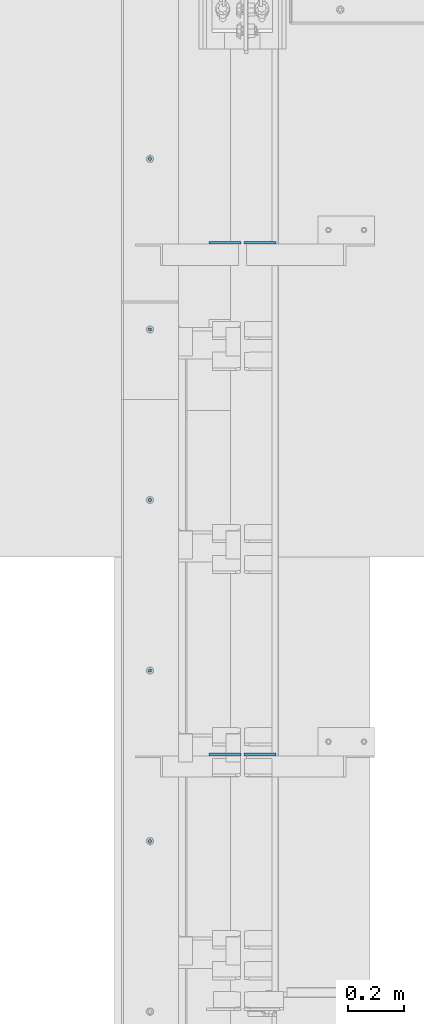
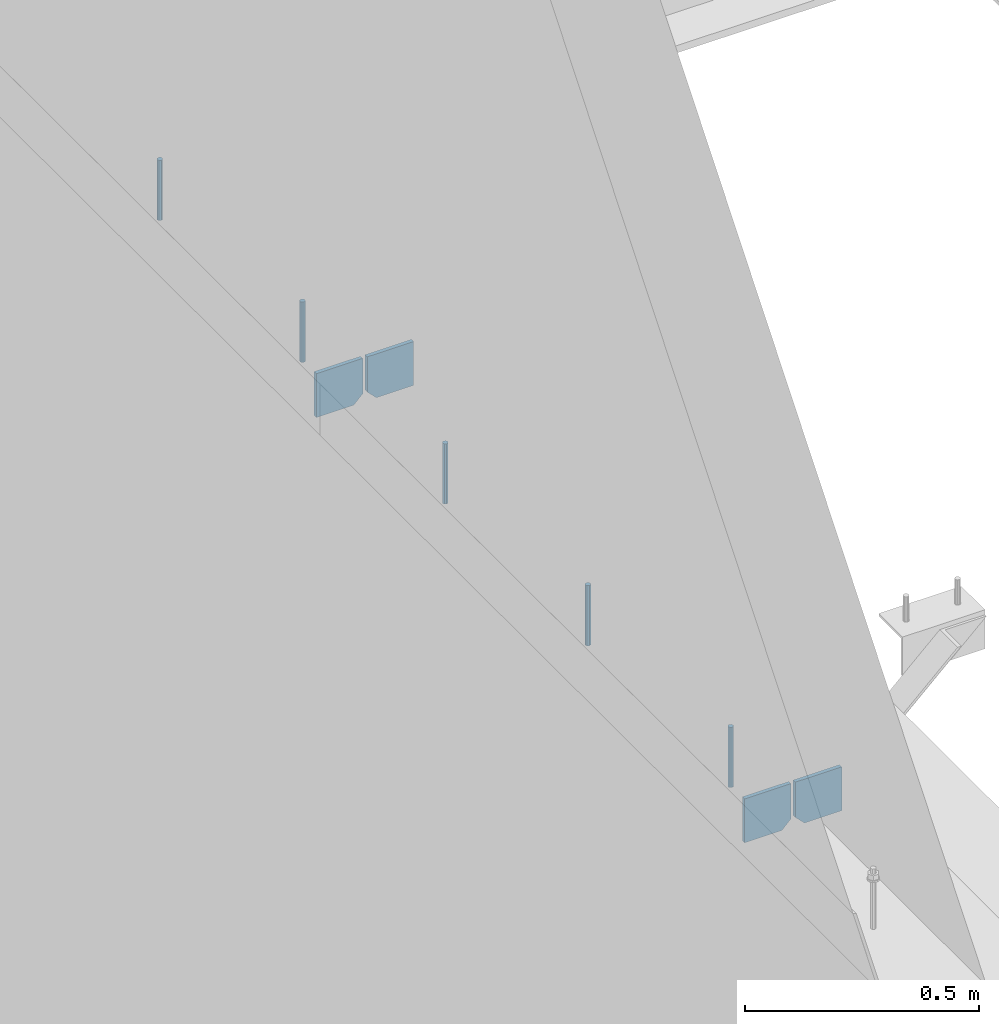
# One storey, part 421 of 1179: 9 columns, 1 element without a shape of its own.
"""IFC2X3 building model written with IfcOpenShell, lengths in millimetres."""

from ifc_helpers import new_model, si_unit, frame, origin_with_axes, place, context, subcontext, project, spatial, faceted_brep, material, type_object, element, aggregate, save


model = new_model("IFC2X3")

# Units and contexts
model_context = context("Model", 3, precision=1e-05, world=origin_with_axes())
body_context = subcontext(model_context, "Body", "Model", "MODEL_VIEW")
ifc_project = project(units=[si_unit("LENGTHUNIT", "METRE", prefix="MILLI"), si_unit("AREAUNIT", "SQUARE_METRE"), si_unit("VOLUMEUNIT", "CUBIC_METRE"), si_unit("MASSUNIT", "GRAM", prefix="KILO"), si_unit("TIMEUNIT", "SECOND"), si_unit("PLANEANGLEUNIT", "RADIAN"), si_unit("SOLIDANGLEUNIT", "STERADIAN"), si_unit("THERMODYNAMICTEMPERATUREUNIT", "DEGREE_CELSIUS"), si_unit("LUMINOUSINTENSITYUNIT", "LUMEN")], contexts=[model_context])

# Site, building, storey
site_placement = place(None, origin_with_axes())
site = spatial("IfcSite", under=ifc_project, at=site_placement, CompositionType="ELEMENT")
building_placement = place(site_placement, origin_with_axes())
building = spatial("IfcBuilding", under=site, at=building_placement, Name="Undefined", CompositionType="ELEMENT")
storey_placement = place(building_placement, origin_with_axes())
storey = spatial("IfcBuildingStorey", under=building, at=storey_placement, Name="Undefined", CompositionType="ELEMENT", Elevation=0.0)

# Assembly, columns
assembly_placement = place(storey_placement, origin_with_axes())
assembly = element("IfcElementAssembly", 1, at=assembly_placement, inside=storey, Name="BEAM", AssemblyPlace="NOTDEFINED", PredefinedType="RIGID_FRAME")
ifc_material_1 = material(Name="STEEL/A36")
column_type_1 = type_object("IfcColumnType", PredefinedType="NOTDEFINED")
column_1_placement = place(assembly_placement, frame((494.506249999995, 25887.3625, 3702.05), z_axis=(-1.0, 0.0, 0.0), x_axis=(0.0, 0.0, 1.0)))
column_1 = element("IfcColumn", 2, at=column_1_placement, type_object=column_type_1, material=ifc_material_1, Name="PLATE", context=body_context, shape_type="Brep", body=[
    faceted_brep([(22.2250000000004, 4.76250000000073, 57.1500000000015), (0.0, 4.76250000000073, 34.9249999999993), (0.0, -4.76250000000073, 34.9249999999993), (22.2250000000004, -4.76250000000073, 57.1500000000015), (114.300000000001, 4.76250000000073, 57.1500000000015), (114.300000000001, 4.76250000000073, -57.1500000000015), (0.0, 4.76250000000073, -57.1500000000015), (114.300000000001, -4.76250000000073, 57.1500000000015), (0.0, -4.76250000000073, -57.1500000000015), (114.300000000001, -4.76250000000073, -57.1500000000015)], [[[0, 1, 2, 3]], [[4, 5, 6, 1, 0]], [[7, 4, 0, 3]], [[8, 9, 7, 3, 2]], [[8, 6, 5, 9]], [[7, 9, 5, 4]], [[6, 8, 2, 1]]]),
])
column_2_placement = place(assembly_placement, frame((369.09375, 25887.3625, 3702.05), z_axis=(1.0, 0.0, 0.0), x_axis=(0.0, 0.0, 1.0)))
column_2 = element("IfcColumn", 3, at=column_2_placement, type_object=column_type_1, material=ifc_material_1, Name="PLATE", context=body_context, shape_type="Brep", body=[
    faceted_brep([(22.2250000000004, 4.76250000000073, 57.1500000000015), (0.0, 4.76250000000073, 34.9249999999993), (0.0, -4.76250000000073, 34.9249999999993), (22.2250000000004, -4.76250000000073, 57.1500000000015), (114.300000000001, 4.76250000000073, 57.1500000000015), (114.300000000001, 4.76250000000073, -57.1500000000015), (0.0, 4.76250000000073, -57.1500000000015), (114.300000000001, -4.76250000000073, 57.1500000000015), (0.0, -4.76250000000073, -57.1500000000015), (114.300000000001, -4.76250000000073, -57.1500000000015)], [[[0, 1, 2, 3]], [[4, 5, 6, 1, 0]], [[7, 4, 0, 3]], [[8, 9, 7, 3, 2]], [[8, 6, 5, 9]], [[7, 9, 5, 4]], [[6, 8, 2, 1]]]),
])
column_3_placement = place(assembly_placement, frame((494.506249999995, 24058.5625, 3702.05), z_axis=(-1.0, 0.0, 0.0), x_axis=(0.0, 0.0, 1.0)))
column_3 = element("IfcColumn", 4, at=column_3_placement, type_object=column_type_1, material=ifc_material_1, Name="PLATE", context=body_context, shape_type="Brep", body=[
    faceted_brep([(22.2250000000004, 4.76250000000073, 57.1500000000015), (0.0, 4.76250000000073, 34.9249999999993), (0.0, -4.76250000000073, 34.9249999999993), (22.2250000000004, -4.76250000000073, 57.1500000000015), (114.300000000001, 4.76250000000073, 57.1500000000015), (114.300000000001, 4.76250000000073, -57.1500000000015), (0.0, 4.76250000000073, -57.1500000000015), (114.300000000001, -4.76250000000073, 57.1500000000015), (0.0, -4.76250000000073, -57.1500000000015), (114.300000000001, -4.76250000000073, -57.1500000000015)], [[[0, 1, 2, 3]], [[4, 5, 6, 1, 0]], [[7, 4, 0, 3]], [[8, 9, 7, 3, 2]], [[8, 6, 5, 9]], [[7, 9, 5, 4]], [[6, 8, 2, 1]]]),
])
column_4_placement = place(assembly_placement, frame((369.09375, 24058.5625, 3702.05), z_axis=(1.0, 0.0, 0.0), x_axis=(0.0, 0.0, 1.0)))
column_4 = element("IfcColumn", 5, at=column_4_placement, type_object=column_type_1, material=ifc_material_1, Name="PLATE", context=body_context, shape_type="Brep", body=[
    faceted_brep([(22.2250000000004, 4.76250000000073, 57.1500000000015), (0.0, 4.76250000000073, 34.9249999999993), (0.0, -4.76250000000073, 34.9249999999993), (22.2250000000004, -4.76250000000073, 57.1500000000015), (114.300000000001, 4.76250000000073, 57.1500000000015), (114.300000000001, 4.76250000000073, -57.1500000000015), (0.0, 4.76250000000073, -57.1500000000015), (114.300000000001, -4.76250000000073, 57.1500000000015), (0.0, -4.76250000000073, -57.1500000000015), (114.300000000001, -4.76250000000073, -57.1500000000015)], [[[0, 1, 2, 3]], [[4, 5, 6, 1, 0]], [[7, 4, 0, 3]], [[8, 9, 7, 3, 2]], [[8, 6, 5, 9]], [[7, 9, 5, 4]], [[6, 8, 2, 1]]]),
])
ifc_material_2 = material(Name="STEEL/A307")
column_type_2 = type_object("IfcColumnType", PredefinedType="NOTDEFINED")
column_5_placement = place(assembly_placement, frame((101.599999999999, 26187.4, 4108.45), z_axis=(0.0, 1.0, 0.0), x_axis=(0.0, 0.0, 1.0)))
column_5 = element("IfcColumn", 6, at=column_5_placement, type_object=column_type_2, material=ifc_material_2, Name="THREADED ROD", context=body_context, shape_type="Brep", body=[
    faceted_brep([(0.0, -6.34999999999854, 0.0), (0.0, -4.49012806053361, -4.49012806053452), (157.162499999999, -4.49012806053361, -4.49012806053361), (157.162499999999, -6.34999999999854, 0.0), (0.0, 0.0, -6.34999999999991), (157.162499999999, 0.0, -6.34999999999854), (0.0, 4.49012806053361, -4.49012806053452), (157.162499999999, 4.49012806053361, -4.49012806053361), (0.0, 6.34999999999854, 0.0), (157.162499999999, 6.34999999999854, 0.0), (0.0, 4.49012806053361, 4.49012806053452), (157.162499999999, 4.49012806053361, 4.49012806053361), (0.0, 0.0, 6.34999999999991), (157.162499999999, 0.0, 6.34999999999854), (0.0, -4.49012806053361, 4.49012806053452), (157.162499999999, -4.49012806053361, 4.49012806053361)], [[[0, 1, 2, 3]], [[1, 4, 5, 2]], [[4, 6, 7, 5]], [[6, 8, 9, 7]], [[8, 10, 11, 9]], [[10, 12, 13, 11]], [[12, 14, 15, 13]], [[14, 0, 3, 15]], [[5, 7, 9, 11, 13, 15, 3, 2]], [[14, 12, 10, 8, 6, 4, 1, 0]]]),
])
column_6_placement = place(assembly_placement, frame((101.599999999999, 25577.8, 4108.45), z_axis=(0.0, 1.0, 0.0), x_axis=(0.0, 0.0, 1.0)))
column_6 = element("IfcColumn", 7, at=column_6_placement, type_object=column_type_2, material=ifc_material_2, Name="THREADED ROD", context=body_context, shape_type="Brep", body=[
    faceted_brep([(0.0, -6.34999999999854, 0.0), (0.0, -4.49012806053361, -4.49012806053452), (157.162499999999, -4.49012806053361, -4.49012806053361), (157.162499999999, -6.34999999999854, 0.0), (0.0, 0.0, -6.34999999999991), (157.162499999999, 0.0, -6.34999999999854), (0.0, 4.49012806053361, -4.49012806053452), (157.162499999999, 4.49012806053361, -4.49012806053361), (0.0, 6.34999999999854, 0.0), (157.162499999999, 6.34999999999854, 0.0), (0.0, 4.49012806053361, 4.49012806053452), (157.162499999999, 4.49012806053361, 4.49012806053361), (0.0, 0.0, 6.34999999999991), (157.162499999999, 0.0, 6.34999999999854), (0.0, -4.49012806053361, 4.49012806053452), (157.162499999999, -4.49012806053361, 4.49012806053361)], [[[0, 1, 2, 3]], [[1, 4, 5, 2]], [[4, 6, 7, 5]], [[6, 8, 9, 7]], [[8, 10, 11, 9]], [[10, 12, 13, 11]], [[12, 14, 15, 13]], [[14, 0, 3, 15]], [[5, 7, 9, 11, 13, 15, 3, 2]], [[14, 12, 10, 8, 6, 4, 1, 0]]]),
])
column_7_placement = place(assembly_placement, frame((101.599999999999, 24968.2, 4108.45), z_axis=(0.0, 1.0, 0.0), x_axis=(0.0, 0.0, 1.0)))
column_7 = element("IfcColumn", 8, at=column_7_placement, type_object=column_type_2, material=ifc_material_2, Name="THREADED ROD", context=body_context, shape_type="Brep", body=[
    faceted_brep([(0.0, -6.34999999999854, 0.0), (0.0, -4.49012806053361, -4.49012806053452), (157.162499999999, -4.49012806053361, -4.49012806053361), (157.162499999999, -6.34999999999854, 0.0), (0.0, 0.0, -6.34999999999991), (157.162499999999, 0.0, -6.34999999999854), (0.0, 4.49012806053361, -4.49012806053452), (157.162499999999, 4.49012806053361, -4.49012806053361), (0.0, 6.34999999999854, 0.0), (157.162499999999, 6.34999999999854, 0.0), (0.0, 4.49012806053361, 4.49012806053452), (157.162499999999, 4.49012806053361, 4.49012806053361), (0.0, 0.0, 6.34999999999991), (157.162499999999, 0.0, 6.34999999999854), (0.0, -4.49012806053361, 4.49012806053452), (157.162499999999, -4.49012806053361, 4.49012806053361)], [[[0, 1, 2, 3]], [[1, 4, 5, 2]], [[4, 6, 7, 5]], [[6, 8, 9, 7]], [[8, 10, 11, 9]], [[10, 12, 13, 11]], [[12, 14, 15, 13]], [[14, 0, 3, 15]], [[5, 7, 9, 11, 13, 15, 3, 2]], [[14, 12, 10, 8, 6, 4, 1, 0]]]),
])
column_8_placement = place(assembly_placement, frame((101.599999999999, 24358.6, 4108.45), z_axis=(0.0, 1.0, 0.0), x_axis=(0.0, 0.0, 1.0)))
column_8 = element("IfcColumn", 9, at=column_8_placement, type_object=column_type_2, material=ifc_material_2, Name="THREADED ROD", context=body_context, shape_type="Brep", body=[
    faceted_brep([(0.0, -6.34999999999854, 0.0), (0.0, -4.49012806053361, -4.49012806053452), (157.162499999999, -4.49012806053361, -4.49012806053361), (157.162499999999, -6.34999999999854, 0.0), (0.0, 0.0, -6.34999999999991), (157.162499999999, 0.0, -6.34999999999854), (0.0, 4.49012806053361, -4.49012806053452), (157.162499999999, 4.49012806053361, -4.49012806053361), (0.0, 6.34999999999854, 0.0), (157.162499999999, 6.34999999999854, 0.0), (0.0, 4.49012806053361, 4.49012806053452), (157.162499999999, 4.49012806053361, 4.49012806053361), (0.0, 0.0, 6.34999999999991), (157.162499999999, 0.0, 6.34999999999854), (0.0, -4.49012806053361, 4.49012806053452), (157.162499999999, -4.49012806053361, 4.49012806053361)], [[[0, 1, 2, 3]], [[1, 4, 5, 2]], [[4, 6, 7, 5]], [[6, 8, 9, 7]], [[8, 10, 11, 9]], [[10, 12, 13, 11]], [[12, 14, 15, 13]], [[14, 0, 3, 15]], [[5, 7, 9, 11, 13, 15, 3, 2]], [[14, 12, 10, 8, 6, 4, 1, 0]]]),
])
column_9_placement = place(assembly_placement, frame((101.599999999999, 23749.0, 4108.45), z_axis=(0.0, 1.0, 0.0), x_axis=(0.0, 0.0, 1.0)))
column_9 = element("IfcColumn", 10, at=column_9_placement, type_object=column_type_2, material=ifc_material_2, Name="THREADED ROD", context=body_context, shape_type="Brep", body=[
    faceted_brep([(0.0, -6.34999999999854, 0.0), (0.0, -4.49012806053361, -4.49012806053452), (157.162499999999, -4.49012806053361, -4.49012806053361), (157.162499999999, -6.34999999999854, 0.0), (0.0, 0.0, -6.34999999999991), (157.162499999999, 0.0, -6.34999999999854), (0.0, 4.49012806053361, -4.49012806053452), (157.162499999999, 4.49012806053361, -4.49012806053361), (0.0, 6.34999999999854, 0.0), (157.162499999999, 6.34999999999854, 0.0), (0.0, 4.49012806053361, 4.49012806053452), (157.162499999999, 4.49012806053361, 4.49012806053361), (0.0, 0.0, 6.34999999999991), (157.162499999999, 0.0, 6.34999999999854), (0.0, -4.49012806053361, 4.49012806053452), (157.162499999999, -4.49012806053361, 4.49012806053361)], [[[0, 1, 2, 3]], [[1, 4, 5, 2]], [[4, 6, 7, 5]], [[6, 8, 9, 7]], [[8, 10, 11, 9]], [[10, 12, 13, 11]], [[12, 14, 15, 13]], [[14, 0, 3, 15]], [[5, 7, 9, 11, 13, 15, 3, 2]], [[14, 12, 10, 8, 6, 4, 1, 0]]]),
])
aggregate(assembly, [column_5, column_6, column_7, column_8, column_9, column_1, column_2, column_3, column_4])

save(model, "model.ifc")
